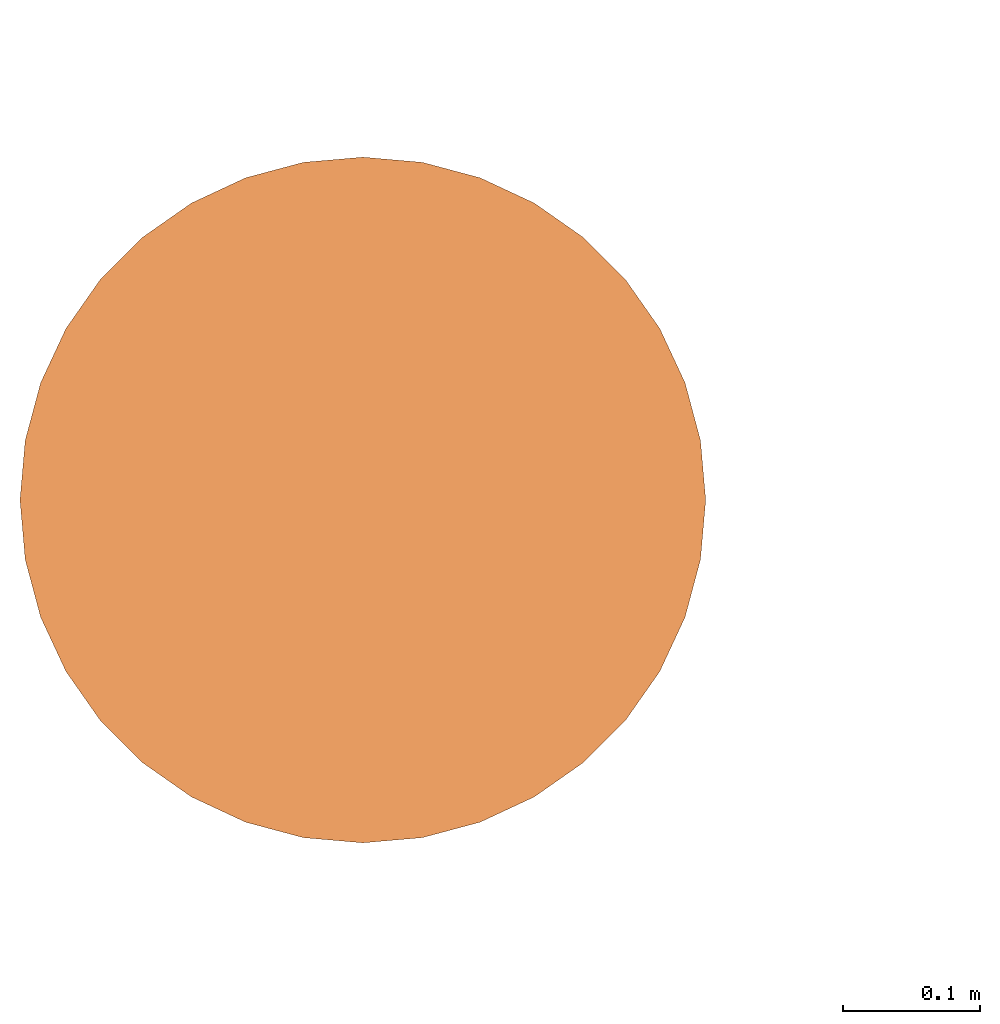
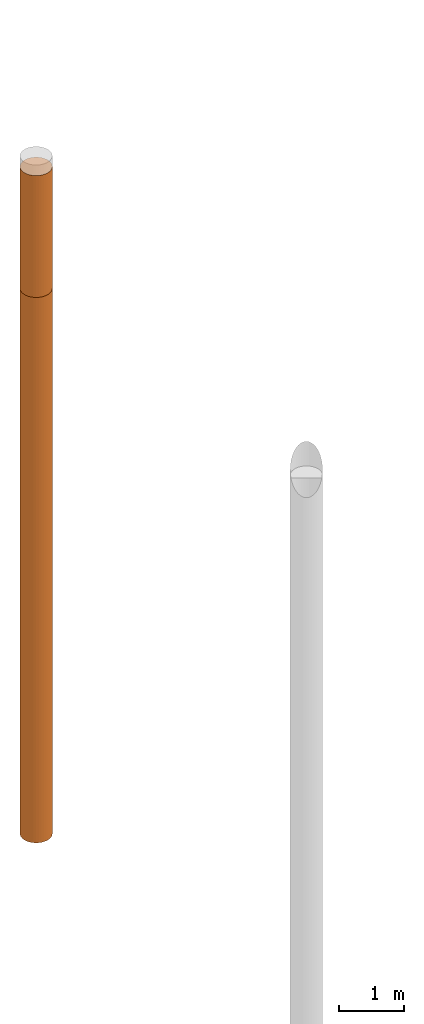
# One storey, part 2 of 8: 2 proxies.
"""IFC4 building model written with IfcOpenShell, lengths in metres."""

from ifc_helpers import new_model, entity, si_unit, converted_unit, frame, origin, place, context, subcontext, project, spatial, faceted_brep, material, element, save


model = new_model("IFC4")

# Units and contexts
model_context = context("Model", 3, precision=1e-05, world=origin())
body_context = subcontext(model_context, "Body", "Model", "MODEL_VIEW")
ifc_project = project(units=[si_unit("LENGTHUNIT", "METRE"), si_unit("AREAUNIT", "SQUARE_METRE"), si_unit("VOLUMEUNIT", "CUBIC_METRE"), converted_unit("PLANEANGLEUNIT", "DEGREE", entity("IfcPlaneAngleMeasure", 0.0174532925199433), si_unit("PLANEANGLEUNIT", "RADIAN"), dimensions=[0, 0, 0, 0, 0, 0, 0])], contexts=[model_context])

# Site, building, storey
site_placement = place(None, origin())
site = spatial("IfcSite", under=ifc_project, at=site_placement, CompositionType="ELEMENT")
building_placement = place(site_placement, origin())
building = spatial("IfcBuilding", under=site, at=building_placement, Name="Demo", CompositionType="ELEMENT")
storey_placement = place(building_placement, origin())
storey = spatial("IfcBuildingStorey", under=building, at=storey_placement, Name="Boden", CompositionType="ELEMENT", Elevation=0.0)

# Proxies
ifc_material_1 = material()
proxy_1_placement = place(storey_placement, frame((1.9, 13.07, -2.5)))
element("IfcBuildingElementProxy", 1, at=proxy_1_placement, inside=storey, material=ifc_material_1, Name="KB-04_Sand", PredefinedType="USERDEFINED", context=body_context, shape_type="Brep", body=[
    faceted_brep([(0.4962019382530516, 0.2934120444167329, 2.3), (0.5, 0.25, 2.3), (0.496201938253052, 0.2065879555832671, 2.3), (0.4849231551964772, 0.1644949641685835, 2.3), (0.4665063509461097, 0.125, 2.3), (0.4415111107797448, 0.08930309757836585, 2.3), (0.4106969024216351, 0.05848888922025617, 2.3), (0.375, 0.0334936490538912, 2.3), (0.3355050358314174, 0.01507684480352327, 2.3), (0.2934120444167325, 0.003798061746947497, 2.3), (0.25, 0.0, 2.3), (0.2065879555832676, 0.003798061746947497, 2.3), (0.164494964168583, 0.01507684480352327, 2.3), (0.125, 0.03349364905388939, 2.3), (0.08930309757836517, 0.05848888922025617, 2.3), (0.05848888922025572, 0.08930309757836585, 2.3), (0.03349364905389052, 0.125, 2.3), (0.01507684480352305, 0.1644949641685835, 2.3), (0.003798061746947951, 0.2065879555832671, 2.3), (0.0, 0.25, 2.3), (0.003798061746947951, 0.2934120444167329, 2.3), (0.01507684480352282, 0.3355050358314166, 2.3), (0.03349364905389007, 0.375, 2.3), (0.05848888922025503, 0.4106969024216342, 2.3), (0.08930309757836472, 0.4415111107797439, 2.3), (0.1249999999999995, 0.4665063509461088, 2.3), (0.1644949641685821, 0.4849231551964767, 2.3), (0.2065879555832667, 0.4962019382530525, 2.3), (0.2499999999999991, 0.5, 2.3), (0.293412044416732, 0.4962019382530525, 2.3), (0.3355050358314166, 0.4849231551964767, 2.3), (0.3749999999999991, 0.4665063509461107, 2.3), (0.4106969024216342, 0.4415111107797456, 2.3), (0.4415111107797439, 0.410696902421636, 2.3), (0.4665063509461093, 0.375, 2.3), (0.4849231551964767, 0.3355050358314184, 2.3), (0.5, 0.25, 0.0), (0.4962019382530516, 0.2934120444167329, 0.0), (0.4849231551964767, 0.3355050358314184, 0.0), (0.4665063509461093, 0.375, 0.0), (0.4415111107797439, 0.410696902421636, 0.0), (0.4106969024216342, 0.4415111107797456, 0.0), (0.3749999999999991, 0.4665063509461107, 0.0), (0.3355050358314166, 0.4849231551964767, 0.0), (0.293412044416732, 0.4962019382530525, 0.0), (0.2499999999999991, 0.5, 0.0), (0.2065879555832667, 0.4962019382530525, 0.0), (0.1644949641685821, 0.4849231551964767, 0.0), (0.1249999999999995, 0.4665063509461088, 0.0), (0.08930309757836472, 0.4415111107797439, 0.0), (0.05848888922025503, 0.4106969024216342, 0.0), (0.03349364905389007, 0.375, 0.0), (0.01507684480352282, 0.3355050358314166, 0.0), (0.003798061746947951, 0.2934120444167311, 0.0), (0.0, 0.25, 0.0), (0.003798061746947951, 0.2065879555832671, 0.0), (0.01507684480352305, 0.1644949641685816, 0.0), (0.03349364905389052, 0.125, 0.0), (0.05848888922025572, 0.08930309757836404, 0.0), (0.08930309757836517, 0.05848888922025435, 0.0), (0.125, 0.03349364905388939, 0.0), (0.164494964168583, 0.01507684480352327, 0.0), (0.2065879555832676, 0.003798061746947497, 0.0), (0.25, 0.0, 0.0), (0.2934120444167325, 0.003798061746947497, 0.0), (0.3355050358314174, 0.01507684480352327, 0.0), (0.375, 0.03349364905388939, 0.0), (0.4106969024216351, 0.05848888922025435, 0.0), (0.4415111107797448, 0.08930309757836404, 0.0), (0.4665063509461097, 0.125, 0.0), (0.4849231551964772, 0.1644949641685816, 0.0), (0.496201938253052, 0.2065879555832671, 0.0), (0.5, 0.25, 2.3), (0.4962019382530516, 0.2934120444167329, 2.3), (0.4962019382530516, 0.2934120444167329, 0.0), (0.5, 0.25, 0.0), (0.496201938253052, 0.2065879555832671, 2.3), (0.5, 0.25, 2.3), (0.5, 0.25, 0.0), (0.496201938253052, 0.2065879555832671, 0.0), (0.4849231551964772, 0.1644949641685835, 2.3), (0.496201938253052, 0.2065879555832671, 2.3), (0.496201938253052, 0.2065879555832671, 0.0), (0.4849231551964772, 0.1644949641685816, 0.0), (0.4665063509461097, 0.125, 2.3), (0.4849231551964772, 0.1644949641685835, 2.3), (0.4849231551964772, 0.1644949641685816, 0.0), (0.4665063509461097, 0.125, 0.0), (0.4415111107797448, 0.08930309757836585, 2.3), (0.4665063509461097, 0.125, 2.3), (0.4665063509461097, 0.125, 0.0), (0.4415111107797448, 0.08930309757836404, 0.0), (0.4106969024216351, 0.05848888922025617, 2.3), (0.4415111107797448, 0.08930309757836585, 2.3), (0.4415111107797448, 0.08930309757836404, 0.0), (0.4106969024216351, 0.05848888922025435, 0.0), (0.375, 0.0334936490538912, 2.3), (0.4106969024216351, 0.05848888922025617, 2.3), (0.4106969024216351, 0.05848888922025435, 0.0), (0.375, 0.03349364905388939, 0.0), (0.3355050358314174, 0.01507684480352327, 2.3), (0.375, 0.0334936490538912, 2.3), (0.375, 0.03349364905388939, 0.0), (0.3355050358314174, 0.01507684480352327, 0.0), (0.2934120444167325, 0.003798061746947497, 2.3), (0.3355050358314174, 0.01507684480352327, 2.3), (0.3355050358314174, 0.01507684480352327, 0.0), (0.2934120444167325, 0.003798061746947497, 0.0), (0.25, 0.0, 2.3), (0.2934120444167325, 0.003798061746947497, 2.3), (0.2934120444167325, 0.003798061746947497, 0.0), (0.25, 0.0, 0.0), (0.2065879555832676, 0.003798061746947497, 2.3), (0.25, 0.0, 2.3), (0.25, 0.0, 0.0), (0.2065879555832676, 0.003798061746947497, 0.0), (0.164494964168583, 0.01507684480352327, 2.3), (0.2065879555832676, 0.003798061746947497, 2.3), (0.2065879555832676, 0.003798061746947497, 0.0), (0.164494964168583, 0.01507684480352327, 0.0), (0.125, 0.03349364905388939, 2.3), (0.164494964168583, 0.01507684480352327, 2.3), (0.164494964168583, 0.01507684480352327, 0.0), (0.125, 0.03349364905388939, 0.0), (0.08930309757836517, 0.05848888922025617, 2.3), (0.125, 0.03349364905388939, 2.3), (0.125, 0.03349364905388939, 0.0), (0.08930309757836517, 0.05848888922025435, 0.0), (0.05848888922025572, 0.08930309757836585, 2.3), (0.08930309757836517, 0.05848888922025617, 2.3), (0.08930309757836517, 0.05848888922025435, 0.0), (0.05848888922025572, 0.08930309757836404, 0.0), (0.03349364905389052, 0.125, 2.3), (0.05848888922025572, 0.08930309757836585, 2.3), (0.05848888922025572, 0.08930309757836404, 0.0), (0.03349364905389052, 0.125, 0.0), (0.01507684480352305, 0.1644949641685835, 2.3), (0.03349364905389052, 0.125, 2.3), (0.03349364905389052, 0.125, 0.0), (0.01507684480352305, 0.1644949641685816, 0.0), (0.003798061746947951, 0.2065879555832671, 2.3), (0.01507684480352305, 0.1644949641685835, 2.3), (0.01507684480352305, 0.1644949641685816, 0.0), (0.003798061746947951, 0.2065879555832671, 0.0), (0.0, 0.25, 2.3), (0.003798061746947951, 0.2065879555832671, 2.3), (0.003798061746947951, 0.2065879555832671, 0.0), (0.0, 0.25, 0.0), (0.003798061746947951, 0.2934120444167329, 2.3), (0.0, 0.25, 2.3), (0.0, 0.25, 0.0), (0.003798061746947951, 0.2934120444167311, 0.0), (0.01507684480352282, 0.3355050358314166, 2.3), (0.003798061746947951, 0.2934120444167329, 2.3), (0.003798061746947951, 0.2934120444167311, 0.0), (0.01507684480352282, 0.3355050358314166, 0.0), (0.03349364905389007, 0.375, 2.3), (0.01507684480352282, 0.3355050358314166, 2.3), (0.01507684480352282, 0.3355050358314166, 0.0), (0.03349364905389007, 0.375, 0.0), (0.05848888922025503, 0.4106969024216342, 2.3), (0.03349364905389007, 0.375, 2.3), (0.03349364905389007, 0.375, 0.0), (0.05848888922025503, 0.4106969024216342, 0.0), (0.08930309757836472, 0.4415111107797439, 2.3), (0.05848888922025503, 0.4106969024216342, 2.3), (0.05848888922025503, 0.4106969024216342, 0.0), (0.08930309757836472, 0.4415111107797439, 0.0), (0.1249999999999995, 0.4665063509461088, 2.3), (0.08930309757836472, 0.4415111107797439, 2.3), (0.08930309757836472, 0.4415111107797439, 0.0), (0.1249999999999995, 0.4665063509461088, 0.0), (0.1644949641685821, 0.4849231551964767, 2.3), (0.1249999999999995, 0.4665063509461088, 2.3), (0.1249999999999995, 0.4665063509461088, 0.0), (0.1644949641685821, 0.4849231551964767, 0.0), (0.2065879555832667, 0.4962019382530525, 2.3), (0.1644949641685821, 0.4849231551964767, 2.3), (0.1644949641685821, 0.4849231551964767, 0.0), (0.2065879555832667, 0.4962019382530525, 0.0), (0.2499999999999991, 0.5, 2.3), (0.2065879555832667, 0.4962019382530525, 2.3), (0.2065879555832667, 0.4962019382530525, 0.0), (0.2499999999999991, 0.5, 0.0), (0.293412044416732, 0.4962019382530525, 2.3), (0.2499999999999991, 0.5, 2.3), (0.2499999999999991, 0.5, 0.0), (0.293412044416732, 0.4962019382530525, 0.0), (0.3355050358314166, 0.4849231551964767, 2.3), (0.293412044416732, 0.4962019382530525, 2.3), (0.293412044416732, 0.4962019382530525, 0.0), (0.3355050358314166, 0.4849231551964767, 0.0), (0.3749999999999991, 0.4665063509461107, 2.3), (0.3355050358314166, 0.4849231551964767, 2.3), (0.3355050358314166, 0.4849231551964767, 0.0), (0.3749999999999991, 0.4665063509461107, 0.0), (0.4106969024216342, 0.4415111107797456, 2.3), (0.3749999999999991, 0.4665063509461107, 2.3), (0.3749999999999991, 0.4665063509461107, 0.0), (0.4106969024216342, 0.4415111107797456, 0.0), (0.4415111107797439, 0.410696902421636, 2.3), (0.4106969024216342, 0.4415111107797456, 2.3), (0.4106969024216342, 0.4415111107797456, 0.0), (0.4415111107797439, 0.410696902421636, 0.0), (0.4665063509461093, 0.375, 2.3), (0.4415111107797439, 0.410696902421636, 2.3), (0.4415111107797439, 0.410696902421636, 0.0), (0.4665063509461093, 0.375, 0.0), (0.4849231551964767, 0.3355050358314184, 2.3), (0.4665063509461093, 0.375, 2.3), (0.4665063509461093, 0.375, 0.0), (0.4849231551964767, 0.3355050358314184, 0.0), (0.4962019382530516, 0.2934120444167329, 2.3), (0.4849231551964767, 0.3355050358314184, 2.3), (0.4849231551964767, 0.3355050358314184, 0.0), (0.4962019382530516, 0.2934120444167329, 0.0)], [[[0, 1, 2, 3, 4, 5, 6, 7, 8, 9, 10, 11, 12, 13, 14, 15, 16, 17, 18, 19, 20, 21, 22, 23, 24, 25, 26, 27, 28, 29, 30, 31, 32, 33, 34, 35]], [[36, 37, 38, 39, 40, 41, 42, 43, 44, 45, 46, 47, 48, 49, 50, 51, 52, 53, 54, 55, 56, 57, 58, 59, 60, 61, 62, 63, 64, 65, 66, 67, 68, 69, 70, 71]], [[72, 73, 74, 75]], [[76, 77, 78, 79]], [[80, 81, 82, 83]], [[84, 85, 86, 87]], [[88, 89, 90, 91]], [[92, 93, 94, 95]], [[96, 97, 98, 99]], [[100, 101, 102, 103]], [[104, 105, 106, 107]], [[108, 109, 110, 111]], [[112, 113, 114, 115]], [[116, 117, 118, 119]], [[120, 121, 122, 123]], [[124, 125, 126, 127]], [[128, 129, 130, 131]], [[132, 133, 134, 135]], [[136, 137, 138, 139]], [[140, 141, 142, 143]], [[144, 145, 146, 147]], [[148, 149, 150, 151]], [[152, 153, 154, 155]], [[156, 157, 158, 159]], [[160, 161, 162, 163]], [[164, 165, 166, 167]], [[168, 169, 170, 171]], [[172, 173, 174, 175]], [[176, 177, 178, 179]], [[180, 181, 182, 183]], [[184, 185, 186, 187]], [[188, 189, 190, 191]], [[192, 193, 194, 195]], [[196, 197, 198, 199]], [[200, 201, 202, 203]], [[204, 205, 206, 207]], [[208, 209, 210, 211]], [[212, 213, 214, 215]]], orient=[[False], [False], [False], [False], [False], [False], [False], [False], [False], [False], [False], [False], [False], [False], [False], [False], [False], [False], [False], [False], [False], [False], [False], [False], [False], [False], [False], [False], [False], [False], [False], [False], [False], [False], [False], [False], [False], [False]]),
])
ifc_material_2 = material()
proxy_2_placement = place(storey_placement, frame((1.9, 13.07, -12.8)))
element("IfcBuildingElementProxy", 2, at=proxy_2_placement, inside=storey, material=ifc_material_2, Name="KB-04_Kies", PredefinedType="USERDEFINED", context=body_context, shape_type="Brep", body=[
    faceted_brep([(0.4962019382530516, 0.2934120444167329, 10.3), (0.5, 0.25, 10.3), (0.496201938253052, 0.2065879555832671, 10.3), (0.4849231551964772, 0.1644949641685835, 10.3), (0.4665063509461097, 0.125, 10.3), (0.4415111107797448, 0.08930309757836585, 10.3), (0.4106969024216351, 0.05848888922025617, 10.3), (0.375, 0.0334936490538912, 10.3), (0.3355050358314174, 0.01507684480352327, 10.3), (0.2934120444167325, 0.003798061746947497, 10.3), (0.25, 0.0, 10.3), (0.2065879555832676, 0.003798061746947497, 10.3), (0.164494964168583, 0.01507684480352327, 10.3), (0.125, 0.03349364905388939, 10.3), (0.08930309757836517, 0.05848888922025617, 10.3), (0.05848888922025572, 0.08930309757836585, 10.3), (0.03349364905389052, 0.125, 10.3), (0.01507684480352305, 0.1644949641685835, 10.3), (0.003798061746947951, 0.2065879555832671, 10.3), (0.0, 0.25, 10.3), (0.003798061746947951, 0.2934120444167329, 10.3), (0.01507684480352282, 0.3355050358314166, 10.3), (0.03349364905389007, 0.375, 10.3), (0.05848888922025503, 0.4106969024216342, 10.3), (0.08930309757836472, 0.4415111107797439, 10.3), (0.1249999999999995, 0.4665063509461088, 10.3), (0.1644949641685821, 0.4849231551964767, 10.3), (0.2065879555832667, 0.4962019382530525, 10.3), (0.2499999999999991, 0.5, 10.3), (0.293412044416732, 0.4962019382530525, 10.3), (0.3355050358314166, 0.4849231551964767, 10.3), (0.3749999999999991, 0.4665063509461107, 10.3), (0.4106969024216342, 0.4415111107797456, 10.3), (0.4415111107797439, 0.410696902421636, 10.3), (0.4665063509461093, 0.375, 10.3), (0.4849231551964767, 0.3355050358314184, 10.3), (0.5, 0.2499999999999982, 0.0), (0.4962019382530516, 0.2934120444167329, 0.0), (0.4849231551964767, 0.3355050358314166, 0.0), (0.4665063509461093, 0.375, 0.0), (0.4415111107797439, 0.4106969024216342, 0.0), (0.4106969024216342, 0.4415111107797439, 0.0), (0.3749999999999991, 0.4665063509461088, 0.0), (0.3355050358314166, 0.4849231551964767, 0.0), (0.293412044416732, 0.4962019382530507, 0.0), (0.2499999999999991, 0.4999999999999982, 0.0), (0.2065879555832667, 0.4962019382530507, 0.0), (0.1644949641685821, 0.4849231551964749, 0.0), (0.1249999999999995, 0.4665063509461088, 0.0), (0.08930309757836472, 0.4415111107797439, 0.0), (0.05848888922025503, 0.4106969024216323, 0.0), (0.03349364905389007, 0.3749999999999982, 0.0), (0.01507684480352282, 0.3355050358314147, 0.0), (0.003798061746947951, 0.2934120444167311, 0.0), (0.0, 0.2499999999999982, 0.0), (0.003798061746947951, 0.2065879555832653, 0.0), (0.01507684480352305, 0.1644949641685816, 0.0), (0.03349364905389052, 0.1249999999999982, 0.0), (0.05848888922025572, 0.08930309757836404, 0.0), (0.08930309757836517, 0.05848888922025435, 0.0), (0.125, 0.03349364905388939, 0.0), (0.164494964168583, 0.01507684480352145, 0.0), (0.2065879555832676, 0.003798061746947497, 0.0), (0.25, -1.818989403545857e-15, 0.0), (0.2934120444167325, 0.003798061746947497, 0.0), (0.3355050358314174, 0.01507684480352145, 0.0), (0.375, 0.03349364905388939, 0.0), (0.4106969024216351, 0.05848888922025435, 0.0), (0.4415111107797448, 0.08930309757836404, 0.0), (0.4665063509461097, 0.1249999999999982, 0.0), (0.4849231551964772, 0.1644949641685816, 0.0), (0.496201938253052, 0.2065879555832653, 0.0), (0.5, 0.25, 10.3), (0.4962019382530516, 0.2934120444167329, 10.3), (0.4962019382530516, 0.2934120444167329, 0.0), (0.5, 0.2499999999999982, 0.0), (0.496201938253052, 0.2065879555832671, 10.3), (0.5, 0.25, 10.3), (0.5, 0.2499999999999982, 0.0), (0.496201938253052, 0.2065879555832653, 0.0), (0.4849231551964772, 0.1644949641685835, 10.3), (0.496201938253052, 0.2065879555832671, 10.3), (0.496201938253052, 0.2065879555832653, 0.0), (0.4849231551964772, 0.1644949641685816, 0.0), (0.4665063509461097, 0.125, 10.3), (0.4849231551964772, 0.1644949641685835, 10.3), (0.4849231551964772, 0.1644949641685816, 0.0), (0.4665063509461097, 0.1249999999999982, 0.0), (0.4415111107797448, 0.08930309757836585, 10.3), (0.4665063509461097, 0.125, 10.3), (0.4665063509461097, 0.1249999999999982, 0.0), (0.4415111107797448, 0.08930309757836404, 0.0), (0.4106969024216351, 0.05848888922025617, 10.3), (0.4415111107797448, 0.08930309757836585, 10.3), (0.4415111107797448, 0.08930309757836404, 0.0), (0.4106969024216351, 0.05848888922025435, 0.0), (0.375, 0.0334936490538912, 10.3), (0.4106969024216351, 0.05848888922025617, 10.3), (0.4106969024216351, 0.05848888922025435, 0.0), (0.375, 0.03349364905388939, 0.0), (0.3355050358314174, 0.01507684480352327, 10.3), (0.375, 0.0334936490538912, 10.3), (0.375, 0.03349364905388939, 0.0), (0.3355050358314174, 0.01507684480352145, 0.0), (0.2934120444167325, 0.003798061746947497, 10.3), (0.3355050358314174, 0.01507684480352327, 10.3), (0.3355050358314174, 0.01507684480352145, 0.0), (0.2934120444167325, 0.003798061746947497, 0.0), (0.25, 0.0, 10.3), (0.2934120444167325, 0.003798061746947497, 10.3), (0.2934120444167325, 0.003798061746947497, 0.0), (0.25, -1.818989403545857e-15, 0.0), (0.2065879555832676, 0.003798061746947497, 10.3), (0.25, 0.0, 10.3), (0.25, -1.818989403545857e-15, 0.0), (0.2065879555832676, 0.003798061746947497, 0.0), (0.164494964168583, 0.01507684480352327, 10.3), (0.2065879555832676, 0.003798061746947497, 10.3), (0.2065879555832676, 0.003798061746947497, 0.0), (0.164494964168583, 0.01507684480352145, 0.0), (0.125, 0.03349364905388939, 10.3), (0.164494964168583, 0.01507684480352327, 10.3), (0.164494964168583, 0.01507684480352145, 0.0), (0.125, 0.03349364905388939, 0.0), (0.08930309757836517, 0.05848888922025617, 10.3), (0.125, 0.03349364905388939, 10.3), (0.125, 0.03349364905388939, 0.0), (0.08930309757836517, 0.05848888922025435, 0.0), (0.05848888922025572, 0.08930309757836585, 10.3), (0.08930309757836517, 0.05848888922025617, 10.3), (0.08930309757836517, 0.05848888922025435, 0.0), (0.05848888922025572, 0.08930309757836404, 0.0), (0.03349364905389052, 0.125, 10.3), (0.05848888922025572, 0.08930309757836585, 10.3), (0.05848888922025572, 0.08930309757836404, 0.0), (0.03349364905389052, 0.1249999999999982, 0.0), (0.01507684480352305, 0.1644949641685835, 10.3), (0.03349364905389052, 0.125, 10.3), (0.03349364905389052, 0.1249999999999982, 0.0), (0.01507684480352305, 0.1644949641685816, 0.0), (0.003798061746947951, 0.2065879555832671, 10.3), (0.01507684480352305, 0.1644949641685835, 10.3), (0.01507684480352305, 0.1644949641685816, 0.0), (0.003798061746947951, 0.2065879555832653, 0.0), (0.0, 0.25, 10.3), (0.003798061746947951, 0.2065879555832671, 10.3), (0.003798061746947951, 0.2065879555832653, 0.0), (0.0, 0.2499999999999982, 0.0), (0.003798061746947951, 0.2934120444167329, 10.3), (0.0, 0.25, 10.3), (0.0, 0.2499999999999982, 0.0), (0.003798061746947951, 0.2934120444167311, 0.0), (0.01507684480352282, 0.3355050358314166, 10.3), (0.003798061746947951, 0.2934120444167329, 10.3), (0.003798061746947951, 0.2934120444167311, 0.0), (0.01507684480352282, 0.3355050358314147, 0.0), (0.03349364905389007, 0.375, 10.3), (0.01507684480352282, 0.3355050358314166, 10.3), (0.01507684480352282, 0.3355050358314147, 0.0), (0.03349364905389007, 0.3749999999999982, 0.0), (0.05848888922025503, 0.4106969024216342, 10.3), (0.03349364905389007, 0.375, 10.3), (0.03349364905389007, 0.3749999999999982, 0.0), (0.05848888922025503, 0.4106969024216323, 0.0), (0.08930309757836472, 0.4415111107797439, 10.3), (0.05848888922025503, 0.4106969024216342, 10.3), (0.05848888922025503, 0.4106969024216323, 0.0), (0.08930309757836472, 0.4415111107797439, 0.0), (0.1249999999999995, 0.4665063509461088, 10.3), (0.08930309757836472, 0.4415111107797439, 10.3), (0.08930309757836472, 0.4415111107797439, 0.0), (0.1249999999999995, 0.4665063509461088, 0.0), (0.1644949641685821, 0.4849231551964767, 10.3), (0.1249999999999995, 0.4665063509461088, 10.3), (0.1249999999999995, 0.4665063509461088, 0.0), (0.1644949641685821, 0.4849231551964749, 0.0), (0.2065879555832667, 0.4962019382530525, 10.3), (0.1644949641685821, 0.4849231551964767, 10.3), (0.1644949641685821, 0.4849231551964749, 0.0), (0.2065879555832667, 0.4962019382530507, 0.0), (0.2499999999999991, 0.5, 10.3), (0.2065879555832667, 0.4962019382530525, 10.3), (0.2065879555832667, 0.4962019382530507, 0.0), (0.2499999999999991, 0.4999999999999982, 0.0), (0.293412044416732, 0.4962019382530525, 10.3), (0.2499999999999991, 0.5, 10.3), (0.2499999999999991, 0.4999999999999982, 0.0), (0.293412044416732, 0.4962019382530507, 0.0), (0.3355050358314166, 0.4849231551964767, 10.3), (0.293412044416732, 0.4962019382530525, 10.3), (0.293412044416732, 0.4962019382530507, 0.0), (0.3355050358314166, 0.4849231551964767, 0.0), (0.3749999999999991, 0.4665063509461107, 10.3), (0.3355050358314166, 0.4849231551964767, 10.3), (0.3355050358314166, 0.4849231551964767, 0.0), (0.3749999999999991, 0.4665063509461088, 0.0), (0.4106969024216342, 0.4415111107797456, 10.3), (0.3749999999999991, 0.4665063509461107, 10.3), (0.3749999999999991, 0.4665063509461088, 0.0), (0.4106969024216342, 0.4415111107797439, 0.0), (0.4415111107797439, 0.410696902421636, 10.3), (0.4106969024216342, 0.4415111107797456, 10.3), (0.4106969024216342, 0.4415111107797439, 0.0), (0.4415111107797439, 0.4106969024216342, 0.0), (0.4665063509461093, 0.375, 10.3), (0.4415111107797439, 0.410696902421636, 10.3), (0.4415111107797439, 0.4106969024216342, 0.0), (0.4665063509461093, 0.375, 0.0), (0.4849231551964767, 0.3355050358314184, 10.3), (0.4665063509461093, 0.375, 10.3), (0.4665063509461093, 0.375, 0.0), (0.4849231551964767, 0.3355050358314166, 0.0), (0.4962019382530516, 0.2934120444167329, 10.3), (0.4849231551964767, 0.3355050358314184, 10.3), (0.4849231551964767, 0.3355050358314166, 0.0), (0.4962019382530516, 0.2934120444167329, 0.0)], [[[0, 1, 2, 3, 4, 5, 6, 7, 8, 9, 10, 11, 12, 13, 14, 15, 16, 17, 18, 19, 20, 21, 22, 23, 24, 25, 26, 27, 28, 29, 30, 31, 32, 33, 34, 35]], [[36, 37, 38, 39, 40, 41, 42, 43, 44, 45, 46, 47, 48, 49, 50, 51, 52, 53, 54, 55, 56, 57, 58, 59, 60, 61, 62, 63, 64, 65, 66, 67, 68, 69, 70, 71]], [[72, 73, 74, 75]], [[76, 77, 78, 79]], [[80, 81, 82, 83]], [[84, 85, 86, 87]], [[88, 89, 90, 91]], [[92, 93, 94, 95]], [[96, 97, 98, 99]], [[100, 101, 102, 103]], [[104, 105, 106, 107]], [[108, 109, 110, 111]], [[112, 113, 114, 115]], [[116, 117, 118, 119]], [[120, 121, 122, 123]], [[124, 125, 126, 127]], [[128, 129, 130, 131]], [[132, 133, 134, 135]], [[136, 137, 138, 139]], [[140, 141, 142, 143]], [[144, 145, 146, 147]], [[148, 149, 150, 151]], [[152, 153, 154, 155]], [[156, 157, 158, 159]], [[160, 161, 162, 163]], [[164, 165, 166, 167]], [[168, 169, 170, 171]], [[172, 173, 174, 175]], [[176, 177, 178, 179]], [[180, 181, 182, 183]], [[184, 185, 186, 187]], [[188, 189, 190, 191]], [[192, 193, 194, 195]], [[196, 197, 198, 199]], [[200, 201, 202, 203]], [[204, 205, 206, 207]], [[208, 209, 210, 211]], [[212, 213, 214, 215]]], orient=[[False], [False], [False], [False], [False], [False], [False], [False], [False], [False], [False], [False], [False], [False], [False], [False], [False], [False], [False], [False], [False], [False], [False], [False], [False], [False], [False], [False], [False], [False], [False], [False], [False], [False], [False], [False], [False], [False]]),
])

save(model, "model.ifc")
